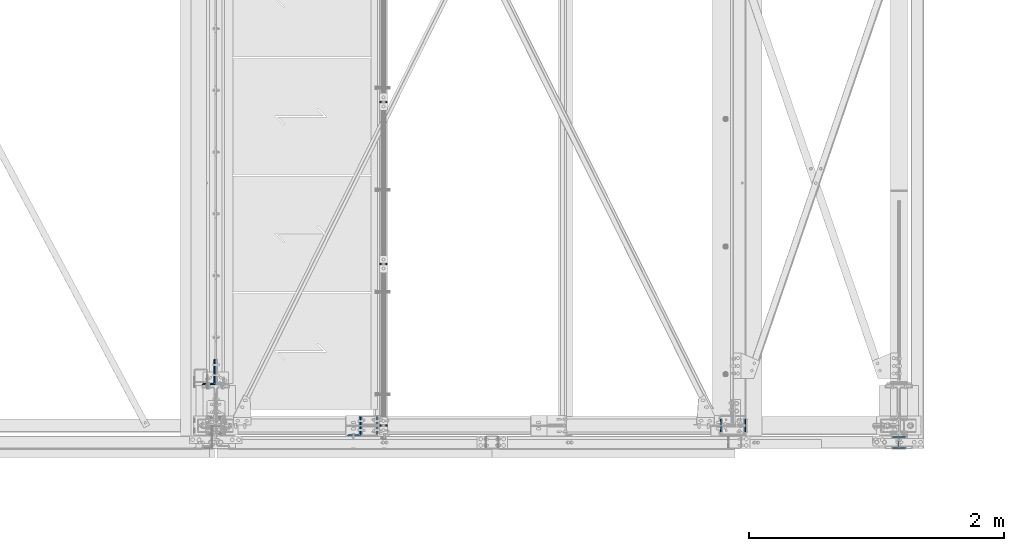
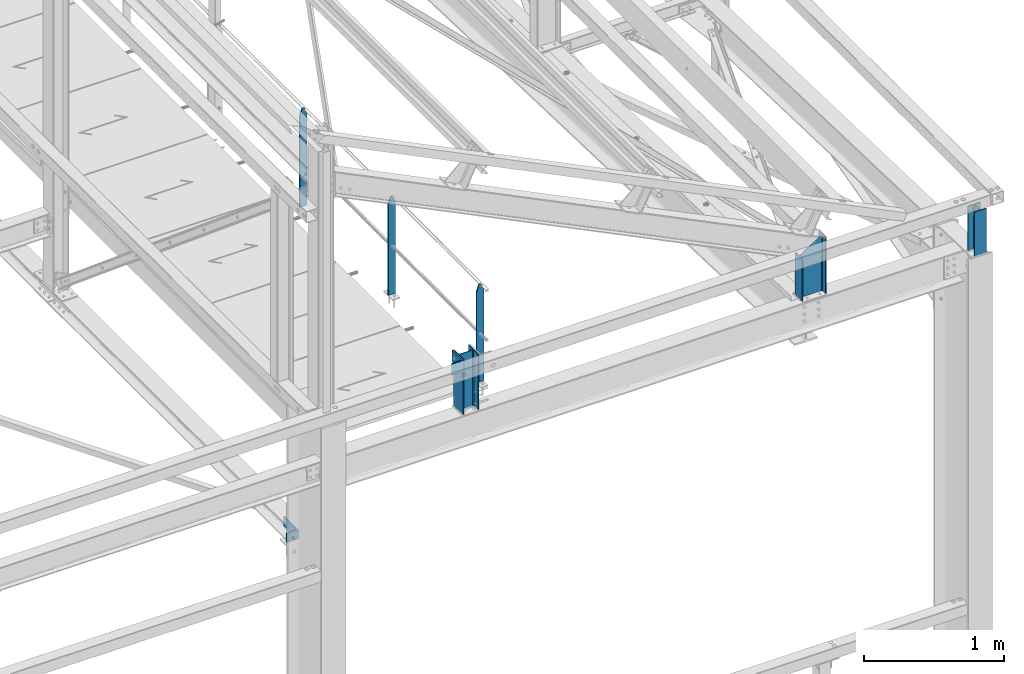
# One storey, part 36 of 496: 8 columns, 6 elements without a shape of their own.
"""IFC2X3 building model written with IfcOpenShell, lengths in millimetres."""

from ifc_helpers import new_model, si_unit, frame, origin_with_axes, origin_2d_with_axis, place, context, subcontext, project, spatial, rectangle, i_section, l_section, extrude, clip, halfspace, material, type_object, element, aggregate, save


model = new_model("IFC2X3")

# Units and contexts
model_context = context("Model", 3, precision=1e-05, world=origin_with_axes())
body_context = subcontext(model_context, "Body", "Model", "MODEL_VIEW")
ifc_project = project(units=[si_unit("LENGTHUNIT", "METRE", prefix="MILLI"), si_unit("AREAUNIT", "SQUARE_METRE"), si_unit("VOLUMEUNIT", "CUBIC_METRE"), si_unit("MASSUNIT", "GRAM", prefix="KILO"), si_unit("TIMEUNIT", "SECOND"), si_unit("PLANEANGLEUNIT", "RADIAN"), si_unit("SOLIDANGLEUNIT", "STERADIAN"), si_unit("THERMODYNAMICTEMPERATUREUNIT", "DEGREE_CELSIUS"), si_unit("LUMINOUSINTENSITYUNIT", "LUMEN")], contexts=[model_context])

# Site, building, storey
site_placement = place(None, origin_with_axes())
site = spatial("IfcSite", under=ifc_project, at=site_placement, CompositionType="ELEMENT")
building_placement = place(site_placement, origin_with_axes())
building = spatial("IfcBuilding", under=site, at=building_placement, Name="Undefined", CompositionType="ELEMENT")
storey_placement = place(building_placement, origin_with_axes())
storey = spatial("IfcBuildingStorey", under=building, at=storey_placement, Name="Undefined", CompositionType="ELEMENT", Elevation=0.0)

# Assembly, columns
assembly_1_placement = place(storey_placement, origin_with_axes())
assembly_1 = element("IfcElementAssembly", 1, at=assembly_1_placement, inside=storey, Name="MAIN COURANTE", AssemblyPlace="NOTDEFINED", PredefinedType="NOTDEFINED")
ifc_material_1 = material(Name="Undefined/S235-E24")
column_type_1 = type_object("IfcColumnType", PredefinedType="NOTDEFINED")
column_1_placement = place(assembly_1_placement, frame((35593.991712357, -8.57210125104757e-07, 8250.00000822896), z_axis=(0.0, 0.0, 1.0), x_axis=(1.0, 0.0, 0.0)))
column_1 = element("IfcColumn", 2, at=column_1_placement, type_object=column_type_1, material=ifc_material_1, Name="MONTANT", context=body_context, shape_type="Clipping", body=[
    clip(clip(extrude(rectangle(XDim=10.0, YDim=60.0, at=origin_2d_with_axis()), frame((0.0, 0.0, 857.599997130677), z_axis=(0.0, 0.0, -1.0), x_axis=(0.0, 1.0, 0.0)), (0.0, 0.0, 1.0), 857.6), halfspace(frame((30.0000001657245, -5.000000004674, 797.599997170884), z_axis=(0.948683298050514, 0.0, 0.316227766016838), x_axis=(-0.316227766016838, 0.0, 0.948683298050514)), False)), halfspace(frame((-29.9999998342682, 4.99999999524351, 797.599997177174), z_axis=(-0.948683298050514, 0.0, 0.316227766016838), x_axis=(0.316227766016838, 0.0, 0.948683298050514)), False)),
])
column_2_placement = place(assembly_1_placement, frame((35593.991712357, 1265.00343196547, 8250.00000822896), z_axis=(0.0, 0.0, 1.0), x_axis=(1.0, 0.0, 0.0)))
column_2 = element("IfcColumn", 3, at=column_2_placement, type_object=column_type_1, material=ifc_material_1, Name="MONTANT", context=body_context, shape_type="Clipping", body=[
    clip(clip(extrude(rectangle(XDim=10.0, YDim=60.0, at=origin_2d_with_axis()), frame((0.0, 0.0, 857.599997130677), z_axis=(0.0, 0.0, -1.0), x_axis=(0.0, 1.0, 0.0)), (0.0, 0.0, 1.0), 857.6), halfspace(frame((30.0000001657245, -5.000000004674, 797.599997170884), z_axis=(0.948683298050514, 0.0, 0.316227766016838), x_axis=(-0.316227766016838, 0.0, 0.948683298050514)), False)), halfspace(frame((-29.9999998342682, 4.99999999524351, 797.599997177174), z_axis=(-0.948683298050514, 0.0, 0.316227766016838), x_axis=(0.316227766016838, 0.0, 0.948683298050514)), False)),
])
column_3_placement = place(assembly_1_placement, frame((35593.9917134121, 2535.00343196547, 8250.00000735839), z_axis=(0.0, 0.0, 1.0), x_axis=(1.0, 0.0, 0.0)))
column_3 = element("IfcColumn", 4, at=column_3_placement, type_object=column_type_1, material=ifc_material_1, Name="MONTANT", context=body_context, shape_type="Clipping", body=[
    clip(clip(extrude(rectangle(XDim=10.0, YDim=60.0, at=origin_2d_with_axis()), frame((0.0, 0.0, 857.599997130677), z_axis=(0.0, 0.0, -1.0), x_axis=(0.0, 1.0, 0.0)), (0.0, 0.0, 1.0), 857.6), halfspace(frame((30.0000001657245, -5.000000004674, 797.599997170884), z_axis=(0.948683298050514, 0.0, 0.316227766016838), x_axis=(-0.316227766016838, 0.0, 0.948683298050514)), False)), halfspace(frame((-29.9999998342682, 4.99999999524351, 797.599997177174), z_axis=(-0.948683298050514, 0.0, 0.316227766016838), x_axis=(0.316227766016838, 0.0, 0.948683298050514)), False)),
])
aggregate(assembly_1, [column_1, column_2, column_3])

# Assembly, column
assembly_2_placement = place(storey_placement, origin_with_axes())
assembly_2 = element("IfcElementAssembly", 5, at=assembly_2_placement, inside=storey, AssemblyPlace="NOTDEFINED", PredefinedType="NOTDEFINED")
column_type_2 = type_object("IfcColumnType", PredefinedType="NOTDEFINED")
column_4_placement = place(assembly_2_placement, frame((35363.4917140619, 20.0, 8450.0), z_axis=(0.0, 0.0, 1.0), x_axis=(0.0, 1.0, 0.0)))
column_4 = element("IfcColumn", 6, at=column_4_placement, type_object=column_type_2, material=ifc_material_1, context=body_context, shape_type="Clipping", body=[
    clip(extrude(l_section(Depth=200.0, Width=100.0, Thickness=10.0, FilletRadius=15.0, EdgeRadius=7.5, at=origin_2d_with_axis()), frame((0.0, 0.0, 100.0), z_axis=(0.0, 0.0, -1.0), x_axis=(0.0, 1.0, 0.0)), (0.0, 0.0, 1.0), 100.0), halfspace(frame((50.0001436217129, -50.0, 100.0), z_axis=(1.0, 0.0, 0.0), x_axis=(0.0, 1.0, 0.0)), False)),
])
aggregate(assembly_2, [column_4])

assembly_3_placement = place(storey_placement, origin_with_axes())
assembly_3 = element("IfcElementAssembly", 7, at=assembly_3_placement, inside=storey, AssemblyPlace="NOTDEFINED", PredefinedType="NOTDEFINED")
column_5_placement = place(assembly_3_placement, frame((34226.4999999302, 419.997266724382, 7143.49999223299), z_axis=(0.0, 0.0, 1.0), x_axis=(0.0, 1.0, 0.0)))
column_5 = element("IfcColumn", 8, at=column_5_placement, type_object=column_type_2, material=ifc_material_1, context=body_context, shape_type="SweptSolid", body=[
    extrude(l_section(Depth=200.0, Width=100.0, Thickness=10.0, FilletRadius=15.0, EdgeRadius=7.5, at=origin_2d_with_axis()), frame((0.0, 0.0, 80.0), z_axis=(0.0, 0.0, -1.0), x_axis=(0.0, 1.0, 0.0)), (0.0, 0.0, 1.0), 80.0),
])
aggregate(assembly_3, [column_5])

assembly_4_placement = place(storey_placement, origin_with_axes())
assembly_4 = element("IfcElementAssembly", 9, at=assembly_4_placement, inside=storey, Name="MONTANT", AssemblyPlace="NOTDEFINED", PredefinedType="NOTDEFINED")
ifc_material_2 = material(Name="Undefined/S275-E28")
column_type_3 = type_object("IfcColumnType", Name="HEA140", PredefinedType="NOTDEFINED")
column_6_placement = place(assembly_4_placement, frame((35479.9917140619, 0.0, 8060.00187330991), z_axis=(0.0, 0.0, 1.0), x_axis=(-1.0, 0.0, 0.0)))
column_6 = element("IfcColumn", 10, at=column_6_placement, type_object=column_type_3, material=ifc_material_2, Name="MONTANT", ObjectType="HEA140", context=body_context, shape_type="Clipping", body=[
    clip(extrude(i_section(OverallWidth=140.0, OverallDepth=133.0, WebThickness=5.5, FlangeThickness=8.5, FilletRadius=12.0, at=origin_2d_with_axis()), frame((0.0, 2.59402848374653e-20, 489.998126690151), z_axis=(0.0, 0.0, -1.0), x_axis=(0.0, 1.0, 0.0)), (0.0, 0.0, 1.0), 492.22), halfspace(frame((66.5, -59.2708727765649, -1.857708645206), z_axis=(0.0, 0.031410477145298, -0.999506569225788), x_axis=(1.0, 0.0, 0.0)), False)),
])
aggregate(assembly_4, [column_6])

assembly_5_placement = place(storey_placement, origin_with_axes())
assembly_5 = element("IfcElementAssembly", 11, at=assembly_5_placement, inside=storey, Name="POTEAU", AssemblyPlace="NOTDEFINED", PredefinedType="NOTDEFINED")
column_type_4 = type_object("IfcColumnType", Name="HEA100", PredefinedType="NOTDEFINED")
column_7_placement = place(assembly_5_placement, frame((39630.0, -132.0, 8049.99544952393), z_axis=(0.0, 0.0, 1.0), x_axis=(0.0, 1.0, 0.0)))
column_7 = element("IfcColumn", 12, at=column_7_placement, type_object=column_type_4, material=ifc_material_2, ObjectType="HEA100", context=body_context, shape_type="Clipping", body=[
    clip(extrude(i_section(OverallWidth=100.0, OverallDepth=96.0, WebThickness=5.0, FlangeThickness=8.0, FilletRadius=12.0, at=origin_2d_with_axis()), frame((0.0, 0.0, 395.004550476075), z_axis=(0.0, 0.0, -1.0), x_axis=(0.0, 1.0, 0.0)), (0.0, 0.0, 1.0), 395.0), halfspace(frame((-48.0, -70.0, 5.66127835062343), z_axis=(-0.0314107590115443, 0.0, -0.999506560367824), x_axis=(0.999506560367824, 0.0, -0.0314107590115582)), False)),
])
aggregate(assembly_5, [column_7])

assembly_6_placement = place(storey_placement, origin_with_axes())
assembly_6 = element("IfcElementAssembly", 13, at=assembly_6_placement, inside=storey, Name="TRAVERSE SHED", AssemblyPlace="NOTDEFINED", PredefinedType="NOTDEFINED")
column_type_5 = type_object("IfcColumnType", Name="IPE200", PredefinedType="NOTDEFINED")
column_8_placement = place(assembly_6_placement, frame((38330.0, 0.0, 8050.00187326879), z_axis=(0.0, 0.0, 1.0), x_axis=(-1.0, 0.0, 0.0)))
column_8 = element("IfcColumn", 14, at=column_8_placement, type_object=column_type_5, material=ifc_material_2, Name="TRAVERSE SHED", ObjectType="IPE200", context=body_context, shape_type="Clipping", body=[
    clip(clip(extrude(i_section(OverallWidth=100.0, OverallDepth=200.0, WebThickness=5.599999905, FlangeThickness=8.5, FilletRadius=12.0, at=origin_2d_with_axis()), frame((0.0, 0.0, 502.207817961787), z_axis=(0.0, 0.0, -1.0), x_axis=(0.0, 1.0, 0.0)), (0.0, 0.0, 1.0), 556.68), halfspace(frame((100.0, 0.0, 375.46503082549), z_axis=(-0.528573112142588, 0.0, -0.848887781229003), x_axis=(0.0, 1.0, 0.0)), True)), halfspace(frame((0.0, 56.4122577955412, 11.7777641156044), z_axis=(0.0, 0.031410477145298, -0.999506569225788), x_axis=(-1.0, 0.0, 0.0)), False)),
])
aggregate(assembly_6, [column_8])

save(model, "model.ifc")
